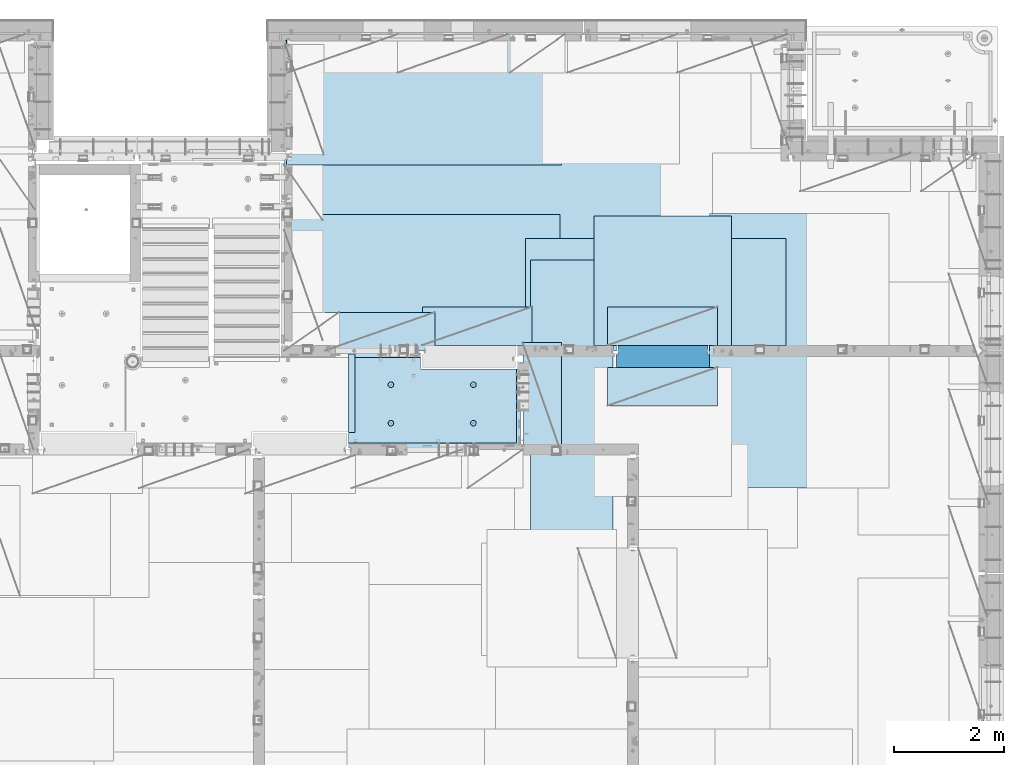
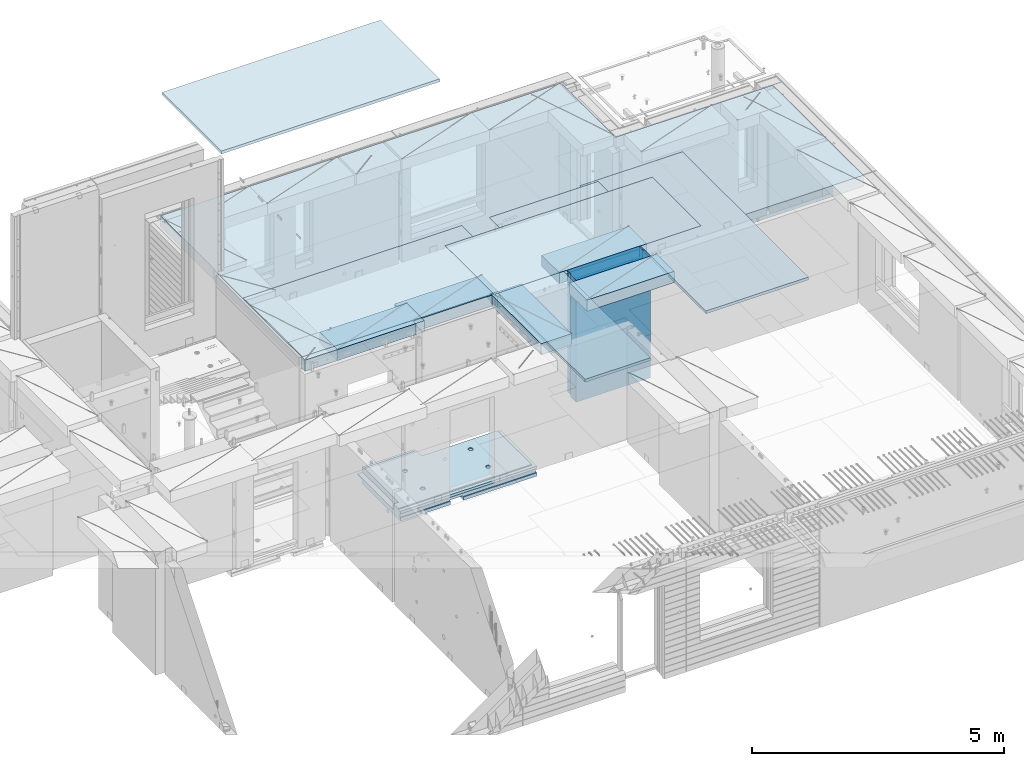
# One storey, part 210 of 352: 12 plates, 2 slabs, 13 elements without a shape of their own.
"""IFC2X3 building model written with IfcOpenShell, lengths in millimetres."""

from ifc_helpers import new_model, si_unit, frame, origin_with_axes, place, context, subcontext, project, spatial, faceted_brep, material, type_object, element, aggregate, save


model = new_model("IFC2X3")

# Units and contexts
model_context = context("Model", 3, precision=1e-05, world=origin_with_axes())
body_context = subcontext(model_context, "Body", "Model", "MODEL_VIEW")
ifc_project = project(units=[si_unit("LENGTHUNIT", "METRE", prefix="MILLI"), si_unit("AREAUNIT", "SQUARE_METRE"), si_unit("VOLUMEUNIT", "CUBIC_METRE"), si_unit("MASSUNIT", "GRAM", prefix="KILO"), si_unit("TIMEUNIT", "SECOND"), si_unit("PLANEANGLEUNIT", "RADIAN"), si_unit("SOLIDANGLEUNIT", "STERADIAN"), si_unit("THERMODYNAMICTEMPERATUREUNIT", "DEGREE_CELSIUS"), si_unit("LUMINOUSINTENSITYUNIT", "LUMEN")], contexts=[model_context])

# Site, building, storey
site_placement = place(None, origin_with_axes())
site = spatial("IfcSite", under=ifc_project, at=site_placement, CompositionType="ELEMENT")
building_placement = place(site_placement, origin_with_axes())
building = spatial("IfcBuilding", under=site, at=building_placement, CompositionType="ELEMENT")
storey_placement = place(building_placement, origin_with_axes())
storey = spatial("IfcBuildingStorey", under=building, at=storey_placement, Name="6", CompositionType="ELEMENT", Elevation=0.0)

# Assembly, slab
assembly_1_placement = place(storey_placement, origin_with_axes())
assembly_1 = element("IfcElementAssembly", 1, at=assembly_1_placement, inside=storey, AssemblyPlace="NOTDEFINED", PredefinedType="REINFORCEMENT_UNIT")
ifc_material_1 = material(Name="CONCRETE/C25/30")
slab_type_1 = type_object("IfcSlabType", PredefinedType="NOTDEFINED")
slab_1_placement = place(assembly_1_placement, frame((26570.0059390845, 15220.0026483125, 96620.0), z_axis=(-0.999999999997437, -2.26400000064461e-06, 0.0), x_axis=(-1.19799915409591e-06, 0.999999999999282, 0.0)))
slab_1 = element("IfcSlab", 2, at=slab_1_placement, type_object=slab_type_1, material=ifc_material_1, PredefinedType="FLOOR", context=body_context, shape_type="Brep", body=[
    faceted_brep([(260.000036693442, 30.0, 20.0001116859203), (260.00040878505, 30.0, 210.00282380305), (760.000392750888, 30.0, 210.001882803081), (760.000035167954, 30.0, 20.0003241859195), (259.999997532928, 50.0008466322761, 0.000110715616756352), (259.999997531775, 130.0, 4.72937244921923e-11), (260.00040878505, 130.0, 210.00282380305), (260.00003669344, 50.0008466322906, 20.0001116859239), (760.000392750888, 130.0, 210.001882803081), (759.999997530887, 50.0009701322706, 0.00188280345173553), (760.000035167954, 50.0009701322851, 20.0003241859267), (759.999997530887, 130.0, 1.4915713109076e-10), (0.0, 130.0, -1.81898940354586e-12), (0.0, 50.0007830199902, -3.63797880709171e-12), (2.23492861550767e-06, 50.0007830199902, 20.0000012144774), (0.00314200731554592, 50.0009709416772, 1679.99820316408), (0.00316042736994859, 130.0, 1679.99820316404), (20.0042037197236, 50.0007871208509, 20.0000019346335), (20.0050448999082, 50.0009732451872, 1679.9981655205), (20.0051981998968, 30.0, 1979.99816552074), (210.003723882246, 30.0, 1979.99780794351), (210.003159282247, 30.0, 1679.99780794404), (20.0050448999027, 30.0, 1679.9981655205), (20.0057858500695, 50.0011356208415, 3129.99855788155), (0.00588817475545511, 50.0011356208415, 3129.99536132812), (0.00371018100122456, 50.0010050132987, 1979.99820316354), (20.0051981998986, 50.0010068401461, 1979.99816552074), (1720.00727399273, -49.9988643791585, 3014.99216831216), (1700.0058891816, -49.9988643791585, 3014.99217713277), (1700.0058891816, 9.99999999994179, 3014.99217713277), (270.007273993393, 9.99999999994179, 3014.99280776216), (270.007273993393, -130.000000000058, 3014.99280776216), (1640.00591170533, -130.000000000058, 3014.99220359276), (1640.00591170533, -110.000000000058, 3014.99220359276), (1720.00727399273, -110.000000000058, 3014.99216831216), (1700.00578510373, 9.99999999994179, 3129.99536132812), (270.007324709519, 9.99999999994179, 3129.99536132812), (1700.00588013352, 9.99999999994179, 3024.99005271558), (270.007324709519, -130.0, 3129.99536132812), (0.0, -49.9992169800098, -3.63797880709171e-12), (1.81898940354586e-12, -110.000000000058, 0.0), (0.00588817475545511, -110.0, 3129.99536132812), (0.00588817475545511, -49.9988643791585, 3129.99536132812), (2.27349282795331e-05, -49.9992169800098, 20.000001214441), (40.0000000237706, -110.0, 0.00323799208854325), (40.0000056179106, -110.0, 80.000116817555), (80.0001648500238, -110.0, 80.0001140175445), (80.0058896111077, -110.0, 3129.99536132811), (80.0001648500238, -130.0, 80.0001140175445), (80.0058896111077, -130.0, 3129.99536132812), (458.262860973307, -110.000000000015, 813.90255309167), (472.201273869185, -110.000000000015, 821.004529187678), (483.262860973307, -110.000000000015, 832.066116291804), (490.364837069317, -110.000000000015, 846.004529187678), (492.812011254558, -110.000000000015, 861.455378906427), (490.364837069317, -110.000000000015, 876.906228625172), (483.262860973307, -110.000000000015, 890.844641521049), (472.201273869185, -110.000000000015, 901.906228625176), (458.262860973306, -110.000000000015, 909.008204721184), (442.81201125456, -110.000000000015, 911.455378906427), (427.361161535811, -110.000000000015, 909.008204721184), (413.422748639936, -110.000000000015, 901.906228625176), (402.361161535813, -110.000000000015, 890.844641521046), (395.259185439802, -110.000000000015, 876.906228625176), (392.81201125456, -110.000000000015, 861.455378906427), (395.259185439802, -110.000000000015, 846.004529187681), (402.361161535813, -110.000000000015, 832.0661162918), (413.422748639936, -110.000000000015, 821.004529187678), (427.361161535813, -110.000000000015, 813.90255309167), (442.812011254558, -110.000000000015, 811.455378906427), (458.965172324157, -130.0, 811.741061009179), (442.812011254558, -130.0, 809.182651633699), (473.537149442574, -130.0, 819.165854200462), (485.101535960521, -130.0, 830.730240718414), (492.526329151806, -130.0, 845.302217836826), (495.084738527285, -130.0, 861.45537890643), (492.526329151804, -130.0, 877.608539976027), (485.101535960521, -130.0, 892.180517094443), (473.537149442574, -130.0, 903.744903612387), (458.965172324157, -130.0, 911.16969680367), (442.81201125456, -130.0, 913.728106179151), (426.658850184962, -130.0, 911.169696803674), (412.086873066544, -130.0, 903.744903612391), (400.522486548598, -130.0, 892.180517094443), (393.097693357315, -130.0, 877.608539976027), (390.539283981834, -130.0, 861.455378906427), (393.097693357317, -130.0, 845.302217836826), (400.522486548598, -130.0, 830.730240718414), (412.086873066544, -130.0, 819.165854200462), (426.658850184962, -130.0, 811.741061009183), (1158.26361347154, -110.000000000058, 2313.90608356011), (1172.20202636741, -110.000000000058, 2321.00805965612), (1183.26361347154, -110.000000000058, 2332.06964676024), (1190.36558956755, -110.000000000058, 2346.00805965611), (1192.81276375279, -110.000000000058, 2361.45890937486), (1190.36558956755, -110.000000000058, 2376.90975909361), (1183.26361347154, -110.000000000058, 2390.84817198949), (1172.20202636741, -110.000000000058, 2401.90975909361), (1158.26361347154, -110.000000000058, 2409.01173518962), (1142.81276375279, -110.000000000058, 2411.45890937487), (1127.36191403404, -110.000000000058, 2409.01173518962), (1113.42350113817, -110.000000000058, 2401.90975909361), (1102.36191403404, -110.000000000058, 2390.84817198948), (1095.25993793803, -110.000000000058, 2376.90975909361), (1092.81276375279, -110.000000000058, 2361.45890937486), (1095.25993793803, -110.000000000058, 2346.00805965612), (1102.36191403404, -110.000000000058, 2332.06964676024), (1113.42350113817, -110.000000000058, 2321.00805965611), (1127.36191403405, -110.000000000058, 2313.90608356011), (1142.81276375279, -110.000000000058, 2311.45890937486), (1158.96592482239, -130.000000000044, 2311.74459147762), (1142.81276375279, -130.000000000044, 2309.18618210214), (1173.5379019408, -130.000000000044, 2319.1693846689), (1185.10228845875, -130.000000000044, 2330.73377118685), (1192.52708165004, -130.000000000044, 2345.30574830526), (1195.08549102551, -130.000000000044, 2361.45890937486), (1192.52708165004, -130.000000000044, 2377.61207044447), (1185.10228845875, -130.000000000044, 2392.18404756288), (1173.5379019408, -130.000000000044, 2403.74843408083), (1158.96592482239, -130.000000000044, 2411.17322727211), (1142.81276375279, -130.000000000044, 2413.73163664759), (1126.65960268319, -130.000000000044, 2411.17322727211), (1112.08762556478, -130.000000000044, 2403.74843408083), (1100.52323904683, -130.000000000044, 2392.18404756287), (1093.09844585554, -130.000000000044, 2377.61207044447), (1090.54003648007, -130.000000000044, 2361.45890937486), (1093.09844585555, -130.000000000044, 2345.30574830526), (1100.52323904683, -130.000000000044, 2330.73377118685), (1112.08762556478, -130.000000000044, 2319.1693846689), (1126.65960268319, -130.000000000044, 2311.74459147762), (1158.26322681425, -110.000000000029, 813.902566246979), (1172.20163971013, -110.000000000029, 821.004542342987), (1183.26322681425, -110.000000000029, 832.066129447114), (1190.36520291026, -110.000000000029, 846.004542342987), (1192.8123770955, -110.000000000029, 861.455392061736), (1190.36520291026, -110.000000000029, 876.906241780482), (1183.26322681425, -110.000000000029, 890.844654676363), (1172.20163971012, -110.000000000029, 901.906241780485), (1158.26322681425, -110.000000000029, 909.008217876493), (1142.8123770955, -110.000000000029, 911.455392061736), (1127.36152737675, -110.000000000029, 909.008217876493), (1113.42311448088, -110.000000000029, 901.906241780485), (1102.36152737675, -110.000000000029, 890.844654676359), (1095.25955128074, -110.000000000029, 876.906241780485), (1092.8123770955, -110.000000000029, 861.45539206174), (1095.25955128074, -110.000000000029, 846.004542342991), (1102.36152737675, -110.000000000029, 832.06612944711), (1113.42311448088, -110.000000000029, 821.004542342987), (1127.36152737675, -110.000000000029, 813.902566246979), (1142.8123770955, -110.000000000029, 811.455392061736), (1158.9655381651, -130.000000000029, 811.741074164489), (1142.8123770955, -130.000000000029, 809.182664789012), (1173.53751528352, -130.000000000029, 819.165867355772), (1185.10190180146, -130.000000000029, 830.730253873724), (1192.52669499275, -130.000000000029, 845.302230992136), (1195.08510436823, -130.000000000029, 861.45539206174), (1192.52669499275, -130.000000000029, 877.608553131337), (1185.10190180146, -130.000000000029, 892.180530249756), (1173.53751528351, -130.000000000029, 903.744916767697), (1158.9655381651, -130.000000000029, 911.16970995898), (1142.8123770955, -130.000000000029, 913.728119334461), (1126.6592160259, -130.000000000029, 911.169709958984), (1112.08723890749, -130.000000000029, 903.7449167677), (1100.52285238954, -130.000000000029, 892.180530249752), (1093.09805919825, -130.000000000029, 877.608553131337), (1090.53964982277, -130.000000000015, 861.455392061736), (1093.09805919826, -130.000000000015, 845.302230992136), (1100.52285238954, -130.000000000015, 830.730253873724), (1112.08723890749, -130.000000000015, 819.165867355776), (1126.6592160259, -130.000000000015, 811.741074164493), (458.263613472778, -110.000000000058, 2313.90740096011), (472.202026368655, -110.000000000058, 2321.00937705611), (483.263613472776, -110.000000000058, 2332.07096416024), (490.365589568788, -110.000000000058, 2346.00937705611), (492.812763754029, -110.000000000058, 2361.46022677486), (490.365589568788, -110.000000000058, 2376.91107649361), (483.263613472778, -110.000000000058, 2390.84948938949), (472.202026368655, -110.000000000058, 2401.91107649361), (458.263613472776, -110.000000000058, 2409.01305258962), (442.812763754029, -110.000000000058, 2411.46022677486), (427.361914035282, -110.000000000058, 2409.01305258962), (413.423501139407, -110.000000000058, 2401.91107649361), (402.361914035284, -110.000000000058, 2390.84948938949), (395.259937939272, -110.000000000058, 2376.91107649361), (392.812763754031, -110.000000000058, 2361.46022677486), (395.259937939272, -110.000000000058, 2346.00937705612), (402.361914035284, -110.000000000058, 2332.07096416024), (413.423501139407, -110.000000000058, 2321.00937705611), (427.361914035284, -110.000000000058, 2313.90740096011), (442.812763754029, -110.000000000058, 2311.46022677486), (458.965924823628, -130.000000000029, 2311.74590887762), (442.812763754029, -130.000000000029, 2309.18749950214), (473.537901942043, -130.000000000029, 2319.1707020689), (485.10228845999, -130.000000000029, 2330.73508858685), (492.527081651273, -130.000000000029, 2345.30706570526), (495.085491026754, -130.000000000029, 2361.46022677486), (492.527081651273, -130.000000000029, 2377.61338784446), (485.102288459992, -130.000000000029, 2392.18536496288), (473.537901942043, -130.000000000029, 2403.74975148082), (458.965924823628, -130.000000000029, 2411.1745446721), (442.812763754031, -130.000000000029, 2413.73295404758), (426.659602684433, -130.000000000029, 2411.17454467211), (412.087625566017, -130.000000000029, 2403.74975148082), (400.523239048071, -130.000000000029, 2392.18536496288), (393.098445856787, -130.000000000029, 2377.61338784446), (390.540036481307, -130.000000000029, 2361.46022677486), (393.098445856789, -130.000000000029, 2345.30706570526), (400.523239048067, -130.000000000029, 2330.73508858685), (412.087625566017, -130.000000000029, 2319.17070206891), (426.659602684433, -130.000000000029, 2311.74590887762), (1640.0069692709, -130.000000000058, 1820.00285259458), (1429.99412576448, -130.0, 80.0005450159842), (1430.00077693619, -130.000000000044, 1820.00324782623), (1640.0069692709, -110.000000000058, 1820.00285259458), (1720.00719314726, -110.000000000058, 1820.00270203416), (1720.00719416424, -49.9988643791585, 1820.00270203415), (1700.00697064704, -49.9988643791585, 1820.00273967458), (1430.00077693619, 129.999999999985, 1820.00324782623), (1720.00507313573, 130.0, 1820.00270203815), (1720.00696350816, 50.0011356208415, 1820.00270203459), (1700.00697064704, 50.0011356208415, 1820.00273967458), (1720.00548380367, 130.0, 2629.9953613439), (1720.00479630696, 50.0011356208415, 2629.99536134425), (1700.00623760369, 50.0011356208415, 2629.99539898154), (1700.00623760369, 30.0, 2629.99539898154), (1700.00578510373, 30.0, 3129.99535793147), (1510.00479630733, 130.0, 2629.99575656425), (1510.00479630733, 30.0, 2629.99575656425), (1510.00573730659, 130.0, 3129.99536132812), (1510.00573730659, 30.0, 3129.99536134176), (0.00588817475545511, 130.0, 3129.99536132812), (20.0057858500695, -49.9988643791585, 3129.99855788155), (0.00372479000361636, 130.0, 1979.99820316351), (210.003723882246, 130.0, 1979.99780794351), (210.003159282247, 130.0, 1679.99780794404), (20.0042037196527, -49.9988643791585, 20.0000019345935), (20.0041864226587, -49.9992128791491, 7.34271452529356e-07), (1429.99419217423, -49.9988643791585, 20.0006089333838), (1429.99420067423, -49.9988643791585, 0.000608933383773547), (80.0000146155362, -110.0, 0.000114017555461032), (1429.99735169022, -110.0, 7.40013310860377e-05), (1429.99412576448, -110.0, 80.0005450159842), (1429.99416747423, 50.0011356208415, 20.0006089334311), (1429.99417597423, 50.0011356208415, 0.000608933431067271), (1429.99735169022, 130.0, 2.80124368146062e-10), (20.0041864225386, 50.0007871208509, -3.03407432511449e-09)], [[[0, 1, 2, 3]], [[4, 5, 6, 1, 0, 7]], [[8, 2, 1, 6]], [[9, 10, 3, 2, 8, 11]], [[12, 13, 14, 15, 16]], [[14, 17, 18, 15]], [[19, 20, 21, 22]], [[23, 24, 25, 26]], [[27, 28, 29, 30, 31, 32, 33, 34]], [[35, 36, 30, 29, 37]], [[31, 30, 36, 38]], [[39, 40, 41, 42, 43]], [[44, 45, 46, 47, 41, 40]], [[48, 49, 47, 46]], [[50, 51, 52, 53, 54, 55, 56, 57, 58, 59, 60, 61, 62, 63, 64, 65, 66, 67, 68, 69]], [[70, 50, 69, 71]], [[72, 51, 50, 70]], [[73, 52, 51, 72]], [[74, 53, 52, 73]], [[75, 54, 53, 74]], [[76, 55, 54, 75]], [[77, 56, 55, 76]], [[78, 57, 56, 77]], [[79, 58, 57, 78]], [[80, 59, 58, 79]], [[81, 60, 59, 80]], [[82, 61, 60, 81]], [[83, 62, 61, 82]], [[84, 63, 62, 83]], [[85, 64, 63, 84]], [[86, 65, 64, 85]], [[87, 66, 65, 86]], [[88, 67, 66, 87]], [[89, 68, 67, 88]], [[71, 69, 68, 89]], [[90, 91, 92, 93, 94, 95, 96, 97, 98, 99, 100, 101, 102, 103, 104, 105, 106, 107, 108, 109]], [[110, 90, 109, 111]], [[112, 91, 90, 110]], [[113, 92, 91, 112]], [[114, 93, 92, 113]], [[115, 94, 93, 114]], [[116, 95, 94, 115]], [[117, 96, 95, 116]], [[118, 97, 96, 117]], [[119, 98, 97, 118]], [[120, 99, 98, 119]], [[121, 100, 99, 120]], [[122, 101, 100, 121]], [[123, 102, 101, 122]], [[124, 103, 102, 123]], [[125, 104, 103, 124]], [[126, 105, 104, 125]], [[127, 106, 105, 126]], [[128, 107, 106, 127]], [[129, 108, 107, 128]], [[111, 109, 108, 129]], [[130, 131, 132, 133, 134, 135, 136, 137, 138, 139, 140, 141, 142, 143, 144, 145, 146, 147, 148, 149]], [[150, 130, 149, 151]], [[152, 131, 130, 150]], [[153, 132, 131, 152]], [[154, 133, 132, 153]], [[155, 134, 133, 154]], [[156, 135, 134, 155]], [[157, 136, 135, 156]], [[158, 137, 136, 157]], [[159, 138, 137, 158]], [[160, 139, 138, 159]], [[161, 140, 139, 160]], [[162, 141, 140, 161]], [[163, 142, 141, 162]], [[164, 143, 142, 163]], [[165, 144, 143, 164]], [[166, 145, 144, 165]], [[167, 146, 145, 166]], [[168, 147, 146, 167]], [[169, 148, 147, 168]], [[151, 149, 148, 169]], [[170, 171, 172, 173, 174, 175, 176, 177, 178, 179, 180, 181, 182, 183, 184, 185, 186, 187, 188, 189]], [[190, 170, 189, 191]], [[192, 171, 170, 190]], [[193, 172, 171, 192]], [[194, 173, 172, 193]], [[195, 174, 173, 194]], [[196, 175, 174, 195]], [[197, 176, 175, 196]], [[198, 177, 176, 197]], [[199, 178, 177, 198]], [[200, 179, 178, 199]], [[201, 180, 179, 200]], [[202, 181, 180, 201]], [[203, 182, 181, 202]], [[204, 183, 182, 203]], [[205, 184, 183, 204]], [[206, 185, 184, 205]], [[207, 186, 185, 206]], [[208, 187, 186, 207]], [[209, 188, 187, 208]], [[191, 189, 188, 209]], [[210, 32, 31, 38, 49, 48, 211, 212], [208, 207, 206, 205, 204, 203, 202, 201, 200, 199, 198, 197, 196, 195, 194, 193, 192, 190, 191, 209], [168, 167, 166, 165, 164, 163, 162, 161, 160, 159, 158, 157, 156, 155, 154, 153, 152, 150, 151, 169], [128, 127, 126, 125, 124, 123, 122, 121, 120, 119, 118, 117, 116, 115, 114, 113, 112, 110, 111, 129], [88, 87, 86, 85, 84, 83, 82, 81, 80, 79, 78, 77, 76, 75, 74, 73, 72, 70, 71, 89]], [[33, 32, 210, 213]], [[34, 33, 213, 214]], [[27, 34, 214, 215]], [[28, 27, 215, 216]], [[214, 213, 210, 212, 217, 218, 219, 220, 216, 215]], [[219, 218, 221, 222]], [[220, 219, 222, 223]], [[35, 37, 29, 28, 216, 220, 223, 224, 225]], [[222, 221, 226, 227, 224, 223]], [[228, 229, 227, 226]], [[224, 227, 229, 225]], [[228, 230, 24, 23, 231, 42, 41, 47, 49, 38, 36, 35, 225, 229]], [[24, 230, 232, 25]], [[233, 20, 19, 26, 25, 232]], [[234, 21, 20, 233]], [[16, 15, 18, 22, 21, 234]], [[17, 235, 231, 23, 26, 19, 22, 18]], [[43, 42, 231, 235]], [[236, 39, 43, 235, 237, 238]], [[239, 44, 40, 39, 236, 238, 240]], [[46, 45, 44, 239, 240, 241]], [[48, 46, 241, 211]], [[240, 238, 237, 242, 243, 244, 217, 212, 211, 241]], [[244, 243, 9, 11]], [[6, 5, 12, 16, 234, 233, 232, 230, 228, 226, 221, 218, 217, 244, 11, 8]], [[245, 13, 12, 5, 4]], [[17, 14, 13, 245, 4, 7]], [[242, 237, 235, 17, 7, 0, 3, 10]], [[243, 242, 10, 9]]]),
])
aggregate(assembly_1, [slab_1])

assembly_2_placement = place(storey_placement, origin_with_axes())
assembly_2 = element("IfcElementAssembly", 3, at=assembly_2_placement, inside=storey, AssemblyPlace="NOTDEFINED", PredefinedType="REINFORCEMENT_UNIT")
ifc_material_2 = material(Name="CONCRETE/C30/37")
slab_type_2 = type_object("IfcSlabType", PredefinedType="NOTDEFINED")
slab_2_placement = place(assembly_2_placement, frame((22310.0, 16980.0, 99595.0), z_axis=(0.0, 1.0, 0.0), x_axis=(1.0, 0.0, 0.0)))
slab_2 = element("IfcSlab", 4, at=slab_2_placement, type_object=slab_type_2, material=ifc_material_2, PredefinedType="FLOOR", context=body_context, shape_type="Brep", body=[
    faceted_brep([(4369.99914550782, -135.0, 99.9999987875526), (4369.99914550782, 135.0, 99.9999987875526), (4369.99914550782, 135.0, 0.0), (4369.99914550782, -135.0, 0.0), (4169.99914550781, -135.0, 99.9997253417969), (4169.99914550781, 135.0, 99.9997253417969), (2489.99914550781, -135.0, 0.0), (2489.99914550781, 135.0, 0.0), (2489.99914550781, 135.0, 99.9997253417969), (2489.99914550781, -135.0, 99.9997253417969), (1.81898940354586e-12, -135.0, 1.81898940354586e-12), (1.81898940354586e-12, 135.0, 1.81898940354586e-12), (-39.9985427856445, -135.0, -0.0037095642182976), (-39.9985427856445, 135.0, -0.0037095642182976), (-40.0, -135.0, 3600.00048828125), (-40.0, 135.0, 3600.00048828125), (-20.0, -135.0, 3600.0), (-20.0, 135.0, 3600.0), (-20.0, -135.0, 5760.0), (-20.0, 135.0, 5760.0), (9149.9990234375, -135.0, 5760.0), (9149.9990234375, 135.0, 5760.0), (9149.9990234375, -135.0, 3600.00073242188), (9149.9990234375, 135.0, 3600.00073242188), (12750.0, -135.0, 3599.9951171875), (12750.0, 135.0, 3599.9951171875), (12750.0, -135.0, 0.0), (12750.0, 135.0, 0.0), (7685.0006429507, -135.0, 0.0), (7685.0006429507, 135.0, 0.0), (7685.0006429507, -135.0, 99.9996630941932), (7685.0006429507, 135.0, 99.9996630941932), (5999.99954431789, -135.0, 99.9996630941932), (5999.99954431789, 135.0, 99.9996630941932), (5999.99954431789, -135.0, 0.0), (5999.99954431789, 135.0, 0.0), (2730.00000000001, 135.0, 99.9997253417969), (2730.00000000001, -135.0, 99.9997253417969)], [[[0, 1, 2, 3]], [[4, 5, 1, 0]], [[6, 7, 8, 9]], [[10, 11, 7, 6]], [[10, 12, 13, 11]], [[12, 14, 15, 13]], [[14, 16, 17, 15]], [[16, 18, 19, 17]], [[18, 20, 21, 19]], [[20, 22, 23, 21]], [[22, 24, 25, 23]], [[24, 26, 27, 25]], [[27, 26, 28, 29]], [[30, 31, 29, 28]], [[32, 33, 31, 30]], [[34, 35, 33, 32]], [[35, 34, 3, 2]], [[36, 8, 7, 11, 13, 15, 17, 19, 21, 23, 25, 27, 29, 31, 33, 35, 2, 1, 5]], [[37, 9, 8, 36, 5, 4]], [[34, 32, 30, 28, 26, 24, 22, 20, 18, 16, 14, 12, 10, 6, 9, 37, 4, 0, 3]]]),
])

# Assembly, plate
assembly_3_placement = place(storey_placement, origin_with_axes())
assembly_3 = element("IfcElementAssembly", 5, at=assembly_3_placement, inside=storey, Name="Steel Assembly", AssemblyPlace="NOTDEFINED", PredefinedType="NOTDEFINED")
ifc_material_3 = material()
plate_type_1 = type_object("IfcPlateType", PredefinedType="NOTDEFINED")
plate_1_placement = place(assembly_3_placement, frame((22309.9998779297, 22710.0009765625, 102695.1), z_axis=(1.0, 0.0, 0.0), x_axis=(0.0, -1.0, 0.0)))
plate_1 = element("IfcPlate", 6, at=plate_1_placement, type_object=plate_type_1, material=ifc_material_3, context=body_context, shape_type="Brep", body=[
    faceted_brep([(0.0, -35.0, 0.0), (0.0, -35.0, 5000.0), (0.0, 35.0, 5000.0), (0.0, 35.0, 0.0), (2349.99951171875, -35.0, 5000.0), (2349.99951171875, 35.0, 5000.0), (2350.0, -35.0, 0.0), (2350.0, 35.0, 0.0)], [[[0, 1, 2, 3]], [[1, 4, 5, 2]], [[4, 6, 7, 5]], [[6, 0, 3, 7]], [[5, 7, 3, 2]], [[6, 4, 1, 0]]]),
])
aggregate(assembly_3, [plate_1])

assembly_4_placement = place(storey_placement, origin_with_axes())
assembly_4 = element("IfcElementAssembly", 7, at=assembly_4_placement, inside=storey, Name="Steel Assembly", AssemblyPlace="NOTDEFINED", PredefinedType="NOTDEFINED")
plate_2_placement = place(assembly_4_placement, frame((22289.9998779297, 19460.0009765625, 99695.1), z_axis=(1.0, 0.0, 0.0), x_axis=(0.0, -1.0, 0.0)))
plate_2 = element("IfcPlate", 8, at=plate_2_placement, type_object=plate_type_1, material=ifc_material_3, context=body_context, shape_type="Brep", body=[
    faceted_brep([(0.0, -35.0, 0.0), (0.0, -35.0, 5000.0), (0.0, 35.0, 5000.0), (0.0, 35.0, 0.0), (2349.99951171875, -35.0, 5000.0), (2349.99951171875, 35.0, 5000.0), (2350.0, -35.0, 0.0), (2350.0, 35.0, 0.0)], [[[0, 1, 2, 3]], [[1, 4, 5, 2]], [[4, 6, 7, 5]], [[6, 0, 3, 7]], [[5, 7, 3, 2]], [[6, 4, 1, 0]]]),
])
aggregate(assembly_4, [plate_2])

assembly_5_placement = place(storey_placement, origin_with_axes())
assembly_5 = element("IfcElementAssembly", 9, at=assembly_5_placement, inside=storey, Name="Steel Assembly", AssemblyPlace="NOTDEFINED", PredefinedType="NOTDEFINED")
plate_3_placement = place(assembly_5_placement, frame((27902.5, 19430.0, 99695.1), z_axis=(1.0, 0.0, 0.0), x_axis=(0.0, -1.0, 0.0)))
plate_3 = element("IfcPlate", 10, at=plate_3_placement, type_object=plate_type_1, material=ifc_material_3, Name="1/2", context=body_context, shape_type="Brep", body=[
    faceted_brep([(0.0, -35.0, 0.0), (0.0, -35.0, 2500.0), (0.0, 35.0, 2500.0), (0.0, 35.0, 0.0), (2349.99951171875, -35.0, 2500.0), (2349.99951171875, 35.0, 2500.0), (2350.0, -35.0, 0.0), (2350.0, 35.0, 0.0)], [[[0, 1, 2, 3]], [[1, 4, 5, 2]], [[4, 6, 7, 5]], [[6, 0, 3, 7]], [[5, 7, 3, 2]], [[6, 4, 1, 0]]]),
])
aggregate(assembly_5, [plate_3])

assembly_6_placement = place(storey_placement, origin_with_axes())
assembly_6 = element("IfcElementAssembly", 11, at=assembly_6_placement, inside=storey, Name="Steel Assembly", AssemblyPlace="NOTDEFINED", PredefinedType="NOTDEFINED")
plate_4_placement = place(assembly_6_placement, frame((32360.0, 19480.0, 99695.1), z_axis=(0.0, -1.0, 0.0), x_axis=(-1.0, 3.00000001838171e-08, 0.0)))
plate_4 = element("IfcPlate", 12, at=plate_4_placement, type_object=plate_type_1, material=ifc_material_3, context=body_context, shape_type="Brep", body=[
    faceted_brep([(0.0, -35.0, 0.0), (0.0, -35.0, 5000.0), (0.0, 35.0, 5000.0), (0.0, 35.0, 0.0), (2349.99951171875, -35.0, 5000.0), (2349.99951171875, 35.0, 5000.0), (2350.0, -35.0, 0.0), (2350.0, 35.0, 0.0)], [[[0, 1, 2, 3]], [[1, 4, 5, 2]], [[4, 6, 7, 5]], [[6, 0, 3, 7]], [[5, 7, 3, 2]], [[6, 4, 1, 0]]]),
])
aggregate(assembly_6, [plate_4])

assembly_7_placement = place(storey_placement, origin_with_axes())
assembly_7 = element("IfcElementAssembly", 13, at=assembly_7_placement, inside=storey, Name="Steel Assembly", AssemblyPlace="NOTDEFINED", PredefinedType="NOTDEFINED")
plate_type_2 = type_object("IfcPlateType", PredefinedType="NOTDEFINED")
plate_5_placement = place(assembly_7_placement, frame((28250.0000122641, 18630.0, 99695.1000003815), z_axis=(0.0, -1.0, 0.0), x_axis=(-1.0, 3.00000001838171e-08, 0.0)))
plate_5 = element("IfcPlate", 14, at=plate_5_placement, type_object=plate_type_2, material=ifc_material_3, context=body_context, shape_type="Brep", body=[
    faceted_brep([(0.0, -35.0, 0.0), (0.0, -35.0, 5000.0), (0.0, 35.0, 5000.0), (0.0, 35.0, 0.0), (1499.99951171875, -35.0, 5000.0), (1499.99951171875, 35.0, 5000.0), (1500.0, -35.0, 0.0), (1500.0, 35.0, 0.0)], [[[0, 1, 2, 3]], [[1, 4, 5, 2]], [[4, 6, 7, 5]], [[6, 0, 3, 7]], [[5, 7, 3, 2]], [[6, 4, 1, 0]]]),
])
aggregate(assembly_7, [plate_5])

assembly_8_placement = place(storey_placement, origin_with_axes())
assembly_8 = element("IfcElementAssembly", 15, at=assembly_8_placement, inside=storey, Name="Steel Assembly", AssemblyPlace="NOTDEFINED", PredefinedType="NOTDEFINED")
plate_type_3 = type_object("IfcPlateType", PredefinedType="NOTDEFINED")
plate_6_placement = place(assembly_8_placement, frame((23010.0008542386, 16980.0001036336, 99595.3), z_axis=(0.0, 1.0, 0.0), x_axis=(1.0, 0.0, 0.0)))
plate_6 = element("IfcPlate", 16, at=plate_6_placement, type_object=plate_type_3, material=ifc_material_3, Name="RE1", context=body_context, shape_type="Brep", body=[
    faceted_brep([(1.81898940354586e-12, -135.0, 1.81898940354586e-12), (0.0, -135.0, 699.999999999996), (0.0, 135.0, 699.999999999996), (1.81898940354586e-12, 135.0, 1.81898940354586e-12), (1999.99951171875, -135.0, 699.999999999993), (1999.99951171875, 135.0, 699.999999999993), (2000.0, -135.0, -3.63797880709171e-12), (2000.0, 135.0, -3.63797880709171e-12)], [[[0, 1, 2, 3]], [[1, 4, 5, 2]], [[4, 6, 7, 5]], [[6, 0, 3, 7]], [[5, 7, 3, 2]], [[6, 4, 1, 0]]]),
])
aggregate(assembly_8, [plate_6])

assembly_9_placement = place(storey_placement, origin_with_axes())
assembly_9 = element("IfcElementAssembly", 17, at=assembly_9_placement, inside=storey, Name="Steel Assembly", AssemblyPlace="NOTDEFINED", PredefinedType="NOTDEFINED")
plate_7_placement = place(assembly_9_placement, frame((30152.4991457614, 16679.9998963664, 99595.3), z_axis=(0.0, -1.0, 0.0), x_axis=(-1.0, 3.00000001838171e-08, 0.0)))
plate_7 = element("IfcPlate", 18, at=plate_7_placement, type_object=plate_type_3, material=ifc_material_3, Name="RE1", context=body_context, shape_type="Brep", body=[
    faceted_brep([(1.81898940354586e-12, -135.0, 1.81898940354586e-12), (0.0, -135.0, 699.999999999996), (0.0, 135.0, 699.999999999996), (1.81898940354586e-12, 135.0, 1.81898940354586e-12), (1999.99951171875, -135.0, 699.999999999993), (1999.99951171875, 135.0, 699.999999999993), (2000.0, -135.0, -3.63797880709171e-12), (2000.0, 135.0, -3.63797880709171e-12)], [[[0, 1, 2, 3]], [[1, 4, 5, 2]], [[4, 6, 7, 5]], [[6, 0, 3, 7]], [[5, 7, 3, 2]], [[6, 4, 1, 0]]]),
])
aggregate(assembly_9, [plate_7])

assembly_10_placement = place(storey_placement, origin_with_axes())
assembly_10 = element("IfcElementAssembly", 19, at=assembly_10_placement, inside=storey, Name="Steel Assembly", AssemblyPlace="NOTDEFINED", PredefinedType="NOTDEFINED")
plate_8_placement = place(assembly_10_placement, frame((28152.5008542386, 17080.0001036336, 99595.3), z_axis=(0.0, 1.0, 0.0), x_axis=(1.0, 0.0, 0.0)))
plate_8 = element("IfcPlate", 20, at=plate_8_placement, type_object=plate_type_3, material=ifc_material_3, Name="RE1", context=body_context, shape_type="Brep", body=[
    faceted_brep([(1.81898940354586e-12, -135.0, 1.81898940354586e-12), (0.0, -135.0, 699.999999999996), (0.0, 135.0, 699.999999999996), (1.81898940354586e-12, 135.0, 1.81898940354586e-12), (1999.99951171875, -135.0, 699.999999999993), (1999.99951171875, 135.0, 699.999999999993), (2000.0, -135.0, -3.63797880709171e-12), (2000.0, 135.0, -3.63797880709171e-12)], [[[0, 1, 2, 3]], [[1, 4, 5, 2]], [[4, 6, 7, 5]], [[6, 0, 3, 7]], [[5, 7, 3, 2]], [[6, 4, 1, 0]]]),
])
aggregate(assembly_10, [plate_8])

assembly_11_placement = place(storey_placement, origin_with_axes())
assembly_11 = element("IfcElementAssembly", 21, at=assembly_11_placement, inside=storey, Name="Steel Assembly", AssemblyPlace="NOTDEFINED", PredefinedType="NOTDEFINED")
plate_9_placement = place(assembly_11_placement, frame((24780.0008542386, 17080.0001036336, 99595.3), z_axis=(0.0, 1.0, 0.0), x_axis=(1.0, 0.0, 0.0)))
plate_9 = element("IfcPlate", 22, at=plate_9_placement, type_object=plate_type_3, material=ifc_material_3, Name="RE1", context=body_context, shape_type="Brep", body=[
    faceted_brep([(1.81898940354586e-12, -135.0, 1.81898940354586e-12), (0.0, -135.0, 699.999999999996), (0.0, 135.0, 699.999999999996), (1.81898940354586e-12, 135.0, 1.81898940354586e-12), (1999.99951171875, -135.0, 699.999999999993), (1999.99951171875, 135.0, 699.999999999993), (2000.0, -135.0, -3.63797880709171e-12), (2000.0, 135.0, -3.63797880709171e-12)], [[[0, 1, 2, 3]], [[1, 4, 5, 2]], [[4, 6, 7, 5]], [[6, 0, 3, 7]], [[5, 7, 3, 2]], [[6, 4, 1, 0]]]),
])
aggregate(assembly_11, [plate_9])

assembly_12_placement = place(storey_placement, origin_with_axes())
assembly_12 = element("IfcElementAssembly", 23, at=assembly_12_placement, inside=storey, Name="Steel Assembly", AssemblyPlace="NOTDEFINED", PredefinedType="NOTDEFINED")
plate_10_placement = place(assembly_12_placement, frame((26609.9998779297, 17130.0, 99595.3), z_axis=(1.0, 0.0, 0.0), x_axis=(0.0, -1.0, 0.0)))
plate_10 = element("IfcPlate", 24, at=plate_10_placement, type_object=plate_type_3, material=ifc_material_3, Name="RE1", context=body_context, shape_type="Brep", body=[
    faceted_brep([(1.81898940354586e-12, -135.0, 1.81898940354586e-12), (0.0, -135.0, 699.999999999996), (0.0, 135.0, 699.999999999996), (1.81898940354586e-12, 135.0, 1.81898940354586e-12), (1999.99951171875, -135.0, 699.999999999993), (1999.99951171875, 135.0, 699.999999999993), (2000.0, -135.0, -3.63797880709171e-12), (2000.0, 135.0, -3.63797880709171e-12)], [[[0, 1, 2, 3]], [[1, 4, 5, 2]], [[4, 6, 7, 5]], [[6, 0, 3, 7]], [[5, 7, 3, 2]], [[6, 4, 1, 0]]]),
])
aggregate(assembly_12, [plate_10])

# Plate
plate_type_4 = type_object("IfcPlateType", PredefinedType="NOTDEFINED")
plate_11_placement = place(assembly_2_placement, frame((31402.0004441066, 19019.9993561238, 99725.45), z_axis=(0.0, -1.0, 0.0), x_axis=(-1.0, 3.00000001838171e-08, 0.0)))
plate_11 = element("IfcPlate", 25, at=plate_11_placement, type_object=plate_type_4, material=ifc_material_3, context=body_context, shape_type="Brep", body=[
    faceted_brep([(0.0, -5.0, 0.0), (0.0, -5.0, 1939.99963378906), (0.0, 5.0, 1939.99963378906), (0.0, 5.0, 0.0), (4742.00048828125, -5.0, 1939.99963378906), (4742.00048828125, 5.0, 1939.99963378906), (4742.00048828125, -5.0, 0.0), (4742.00048828125, 5.0, 0.0), (92.0009613037109, -5.0, 0.0), (92.0009613037109, 5.0, 0.0)], [[[0, 1, 2, 3]], [[1, 4, 5, 2]], [[4, 6, 7, 5]], [[6, 8, 9, 7]], [[8, 0, 3, 9]], [[5, 7, 9, 3, 2]], [[8, 6, 4, 1, 0]]]),
])

aggregate(assembly_2, [plate_11, slab_2])

# Assembly, plate
assembly_13_placement = place(storey_placement, origin_with_axes())
assembly_13 = element("IfcElementAssembly", 26, at=assembly_13_placement, inside=storey, Name="Steel Assembly", AssemblyPlace="NOTDEFINED", PredefinedType="NOTDEFINED")
ifc_material_4 = material()
plate_type_5 = type_object("IfcPlateType", PredefinedType="NOTDEFINED")
plate_12_placement = place(assembly_13_placement, frame((28309.9999105288, 16680.0000293051, 98255.6000003815), z_axis=(0.0, 1.0, 0.0), x_axis=(1.0, 0.0, 0.0)))
plate_12 = element("IfcPlate", 27, at=plate_12_placement, type_object=plate_type_5, material=ifc_material_4, context=body_context, shape_type="Brep", body=[
    faceted_brep([(29.9999989126591, -1475.0, 243.000885767418), (29.9999989126591, 1475.0, 243.000885767418), (0.0, 1475.0, 230.000886222213), (0.0, -1475.0, 230.000886222213), (30.0000025741901, -1475.0, 399.999635204884), (30.0000025741901, 1475.0, 399.999633789063), (1700.00073242188, -1475.0, 0.0), (0.0, -1475.0, 0.0), (0.0, 1475.0, 0.0), (1700.00073242188, 1475.0, 0.0), (1700.00073242188, 1475.0, 230.001129150391), (1700.00041094652, -1475.0, 230.001129150391), (1670.00041094652, 1475.0, 243.001129150391), (1670.00041094652, -1475.0, 243.001129150391), (1670.00041094652, -1475.0, 399.999633789063), (1670.00041094652, 1475.0, 399.999633789063)], [[[0, 1, 2, 3]], [[4, 5, 1, 0]], [[6, 7, 8, 9]], [[6, 9, 10, 11]], [[11, 10, 12, 13]], [[14, 13, 12, 15]], [[3, 7, 6, 11, 13, 14, 4, 0]], [[8, 7, 3, 2]], [[15, 12, 10, 9, 8, 2, 1, 5]], [[14, 15, 5, 4]]]),
])
aggregate(assembly_13, [plate_12])

save(model, "model.ifc")
